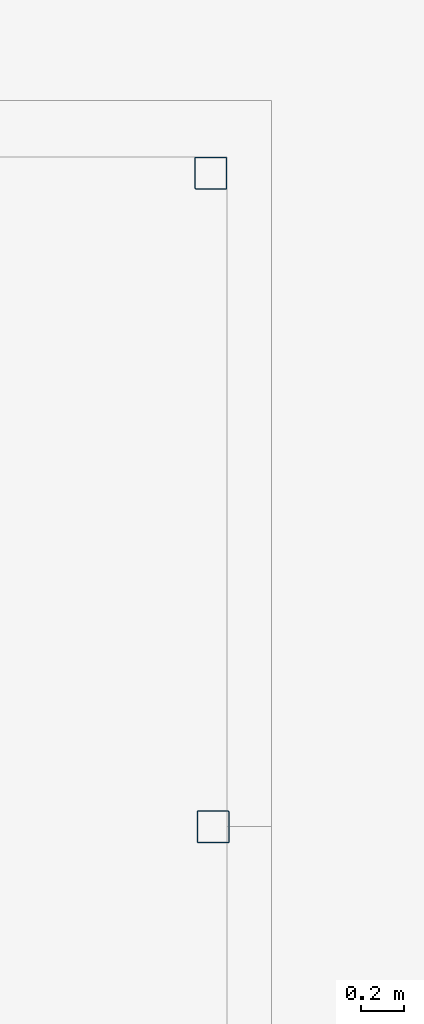
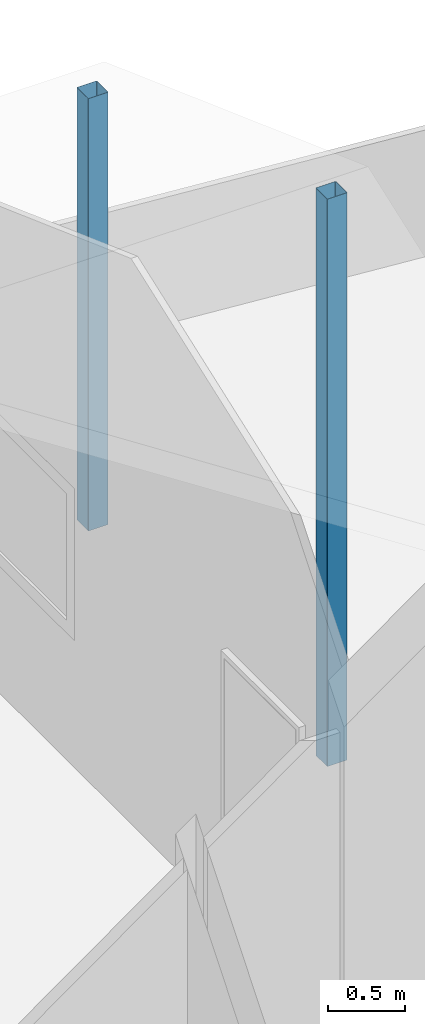
# One storey, part 1 of 4: 2 columns.
"""IFC4 building model written with IfcOpenShell, lengths in millimetres."""

from ifc_helpers import new_model, entity, si_unit, converted_unit, frame, origin_with_axes, origin_2d_with_axis, place, context, subcontext, project, spatial, hollow_rectangle, extrude, material, material_profile, profile_set, profile_usage, type_object, element, save


model = new_model("IFC4")

# Units and contexts
model_context = context("Model", 3, precision=1e-05, world=origin_with_axes())
plan_context = context("Plan", 2, precision=1e-05, world=origin_2d_with_axis())
body_context = subcontext(model_context, "Body", "Model", "MODEL_VIEW")
ifc_project = project(units=[converted_unit("PLANEANGLEUNIT", "degree", entity("IfcReal", 0.0174532925199433), si_unit("PLANEANGLEUNIT", "RADIAN"), dimensions=[0, 0, 0, 0, 0, 0, 0]), si_unit("AREAUNIT", "SQUARE_METRE"), si_unit("VOLUMEUNIT", "CUBIC_METRE"), si_unit("LENGTHUNIT", "METRE", prefix="MILLI")], contexts=[model_context, plan_context])

# Site, building, storey
site_placement = place(None, origin_with_axes())
site = spatial("IfcSite", under=ifc_project, at=site_placement)
building_placement = place(site_placement, origin_with_axes())
building = spatial("IfcBuilding", under=site, at=building_placement, Name="Building")
storey_placement = place(building_placement, origin_with_axes())
storey = spatial("IfcBuildingStorey", under=building, at=storey_placement, Name="Storey")

# Columns
ifc_material = material()
ifc_material_profile = material_profile(ifc_material, hollow_rectangle(XDim=150.0, YDim=150.0, WallThickness=2.0, InnerFilletRadius=5.0, OuterFilletRadius=5.0))
ifc_profile_set = profile_set([ifc_material_profile])
ifc_profile_usage_1 = profile_usage(ifc_profile_set, cardinal=5)
column_type = type_object("IfcColumnType", Name="C1 15 x 15cm", PredefinedType="NOTDEFINED", material=ifc_profile_set)
column_1_placement = place(storey_placement, frame((12985.050201416, -5825.70171356201, 0.0), z_axis=(0.0, 0.0, 1.0), x_axis=(1.0, 0.0, 0.0)))
element("IfcColumn", 1, at=column_1_placement, inside=storey, type_object=column_type, material=ifc_profile_usage_1, Name="Column", context=body_context, shape_type="SweptSolid", body=[
    extrude(hollow_rectangle(XDim=150.0, YDim=150.0, WallThickness=2.0, InnerFilletRadius=5.0, OuterFilletRadius=5.0), origin_with_axes(), (0.0, 0.0, 1.0), 4476.13661838971),
])
ifc_profile_usage_2 = profile_usage(ifc_profile_set, cardinal=5)
column_2_placement = place(storey_placement, frame((12975.0003814697, -2755.0003528595, 0.0), z_axis=(0.0, 0.0, 1.0), x_axis=(1.0, 0.0, 0.0)))
element("IfcColumn", 2, at=column_2_placement, inside=storey, type_object=column_type, material=ifc_profile_usage_2, Name="Column", context=body_context, shape_type="SweptSolid", body=[
    extrude(hollow_rectangle(XDim=150.0, YDim=150.0, WallThickness=2.0, InnerFilletRadius=5.0, OuterFilletRadius=5.0), origin_with_axes(), (0.0, 0.0, 1.0), 3411.16664115061),
])

save(model, "model.ifc")
